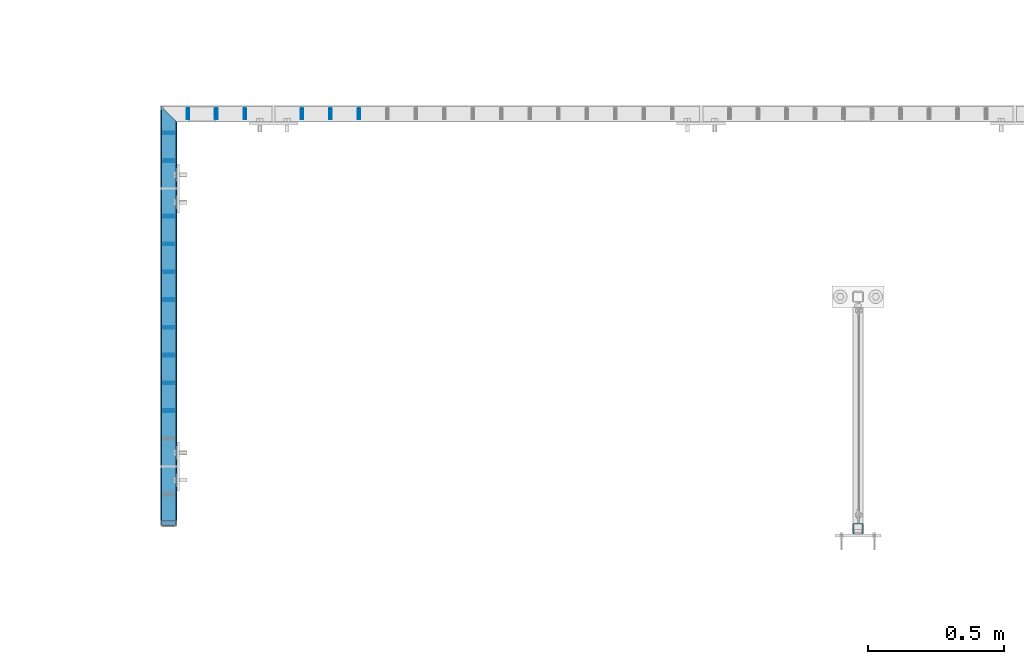
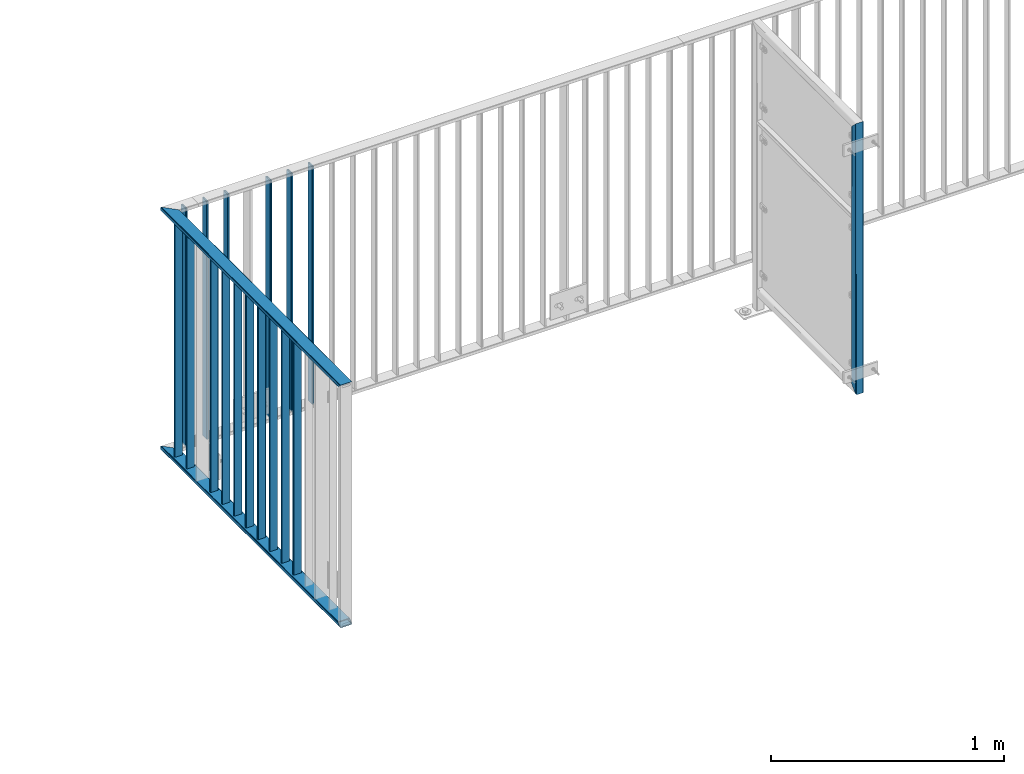
# One storey, part 25 of 156: 19 beams, 3 elements without a shape of their own.
"""IFC2X3 building model written with IfcOpenShell, lengths in millimetres."""

from ifc_helpers import new_model, si_unit, frame, origin_with_axes, origin_2d_with_axis, place, context, subcontext, project, spatial, hollow_rectangle, extrude, clip, halfspace, material, type_object, element, aggregate, save


model = new_model("IFC2X3")

# Units and contexts
model_context = context("Model", 3, precision=1e-05, world=origin_with_axes())
body_context = subcontext(model_context, "Body", "Model", "MODEL_VIEW")
ifc_project = project(units=[si_unit("LENGTHUNIT", "METRE", prefix="MILLI"), si_unit("AREAUNIT", "SQUARE_METRE"), si_unit("VOLUMEUNIT", "CUBIC_METRE"), si_unit("MASSUNIT", "GRAM", prefix="KILO"), si_unit("TIMEUNIT", "SECOND"), si_unit("PLANEANGLEUNIT", "RADIAN"), si_unit("SOLIDANGLEUNIT", "STERADIAN"), si_unit("THERMODYNAMICTEMPERATUREUNIT", "DEGREE_CELSIUS"), si_unit("LUMINOUSINTENSITYUNIT", "LUMEN")], contexts=[model_context])

# Site, building, storey
site_placement = place(None, origin_with_axes())
site = spatial("IfcSite", under=ifc_project, at=site_placement, CompositionType="ELEMENT")
building_placement = place(site_placement, origin_with_axes())
building = spatial("IfcBuilding", under=site, at=building_placement, Name="Undefined", CompositionType="ELEMENT")
storey_placement = place(building_placement, origin_with_axes())
storey = spatial("IfcBuildingStorey", under=building, at=storey_placement, Name="Undefined", CompositionType="ELEMENT", Elevation=0.0)

# Assembly, beams
assembly_1_placement = place(storey_placement, origin_with_axes())
assembly_1 = element("IfcElementAssembly", 1, at=assembly_1_placement, inside=storey, AssemblyPlace="NOTDEFINED", PredefinedType="RIGID_FRAME")
ifc_material = material(Name="STEEL/S235JR")
beam_type_1 = type_object("IfcBeamType", Name="K60/20/2", PredefinedType="NOTDEFINED")
beam_1_placement = place(assembly_1_placement, frame((31474.9983520508, 21631.4407649855, 2740.0), z_axis=(1.0, 0.0, 0.0), x_axis=(0.0, -1.0, 0.0)))
beam_1 = element("IfcBeam", 2, at=beam_1_placement, type_object=beam_type_1, material=ifc_material, ObjectType="K60/20/2", context=body_context, shape_type="Clipping", body=[
    clip(clip(extrude(hollow_rectangle(XDim=20.0, YDim=60.0, WallThickness=2.0, InnerFilletRadius=2.0, OuterFilletRadius=4.0, at=origin_2d_with_axis()), frame((1513.83911766303, 0.0, 0.0), z_axis=(-1.0, 0.0, 0.0), x_axis=(0.0, -1.0, 0.0)), (0.0, 0.0, 1.0), 1580.79), halfspace(frame((1483.43911766303, 10.0, 0.002166748046875), z_axis=(-0.707106781186548, 0.707106781186548, 0.0), x_axis=(0.0, 0.0, 1.0)), True)), halfspace(frame((3.44877025730966, 0.0, 30.0), z_axis=(-0.707106781186548, 0.0, 0.707106781186548), x_axis=(0.0, -1.0, 0.0)), False)),
])
beam_2_placement = place(assembly_1_placement, frame((31474.9983520508, 21631.4407649855, 3990.0), z_axis=(1.0, 0.0, 0.0), x_axis=(0.0, -1.0, 0.0)))
beam_2 = element("IfcBeam", 3, at=beam_2_placement, type_object=beam_type_1, material=ifc_material, ObjectType="K60/20/2", context=body_context, shape_type="Clipping", body=[
    clip(clip(extrude(hollow_rectangle(XDim=20.0, YDim=60.0, WallThickness=2.0, InnerFilletRadius=2.0, OuterFilletRadius=4.0, at=origin_2d_with_axis()), frame((1513.83911766303, 0.0, 0.0), z_axis=(-1.0, 0.0, 0.0), x_axis=(0.0, -1.0, 0.0)), (0.0, 0.0, 1.0), 1580.79), halfspace(frame((1463.43911766303, 10.0, 0.002166748046875), z_axis=(-0.707106781186548, -0.707106781186548, 0.0), x_axis=(0.0, 0.0, 1.0)), True)), halfspace(frame((-56.5512297426903, 0.0, -30.0), z_axis=(0.707106781186548, 0.0, -0.707106781186548), x_axis=(0.0, -1.0, 0.0)), True)),
])
beam_type_2 = type_object("IfcBeamType", Name="K40/10/1.5", PredefinedType="NOTDEFINED")
beam_3_placement = place(assembly_1_placement, frame((31474.9983597497, 20570.1907649865, 3980.00000000003), z_axis=(1.0, 0.0, 0.0), x_axis=(0.0, 0.0, -1.0)))
beam_3 = element("IfcBeam", 4, at=beam_3_placement, type_object=beam_type_2, material=ifc_material, ObjectType="K40/10/1.5", context=body_context, shape_type="Clipping", body=[
    clip(clip(extrude(hollow_rectangle(XDim=10.0, YDim=40.0, WallThickness=1.5, InnerFilletRadius=1.5, OuterFilletRadius=3.0, at=origin_2d_with_axis()), frame((1237.00000000003, 0.0, 0.0), z_axis=(-1.0, 0.0, 0.0), x_axis=(0.0, -1.0, 0.0)), (0.0, 0.0, 1.0), 1244.0), halfspace(frame((1237.00000000003, 3.63803898150218, 46.7940496082883), z_axis=(1.0, 0.0, 0.0), x_axis=(0.0, -0.758923924280425, -0.65117929724063)), False)), halfspace(frame((-6.99999999997453, -3.63803898149854, 46.7940496082956), z_axis=(-1.0, 0.0, 0.0), x_axis=(0.0, 0.75892392428044, -0.651179297240612)), False)),
])
beam_4_placement = place(assembly_1_placement, frame((31474.9983597497, 20671.9707649865, 3980.00000000003), z_axis=(1.0, 0.0, 0.0), x_axis=(0.0, 0.0, -1.0)))
beam_4 = element("IfcBeam", 5, at=beam_4_placement, type_object=beam_type_2, material=ifc_material, ObjectType="K40/10/1.5", context=body_context, shape_type="Clipping", body=[
    clip(clip(extrude(hollow_rectangle(XDim=10.0, YDim=40.0, WallThickness=1.5, InnerFilletRadius=1.5, OuterFilletRadius=3.0, at=origin_2d_with_axis()), frame((1237.00000000003, 0.0, 0.0), z_axis=(-1.0, 0.0, 0.0), x_axis=(0.0, -1.0, 0.0)), (0.0, 0.0, 1.0), 1244.0), halfspace(frame((1237.00000000003, 3.63803898150218, 46.7940496082883), z_axis=(1.0, 0.0, 0.0), x_axis=(0.0, -0.758923924280425, -0.65117929724063)), False)), halfspace(frame((-6.99999999997453, -3.63803898149854, 46.7940496082956), z_axis=(-1.0, 0.0, 0.0), x_axis=(0.0, 0.75892392428044, -0.651179297240612)), False)),
])
beam_5_placement = place(assembly_1_placement, frame((31474.9983597497, 20773.7507649865, 3980.00000000003), z_axis=(1.0, 0.0, 0.0), x_axis=(0.0, 0.0, -1.0)))
beam_5 = element("IfcBeam", 6, at=beam_5_placement, type_object=beam_type_2, material=ifc_material, ObjectType="K40/10/1.5", context=body_context, shape_type="Clipping", body=[
    clip(clip(extrude(hollow_rectangle(XDim=10.0, YDim=40.0, WallThickness=1.5, InnerFilletRadius=1.5, OuterFilletRadius=3.0, at=origin_2d_with_axis()), frame((1237.00000000003, 0.0, 0.0), z_axis=(-1.0, 0.0, 0.0), x_axis=(0.0, -1.0, 0.0)), (0.0, 0.0, 1.0), 1244.0), halfspace(frame((1237.00000000003, 3.63803898150218, 46.7940496082883), z_axis=(1.0, 0.0, 0.0), x_axis=(0.0, -0.758923924280425, -0.65117929724063)), False)), halfspace(frame((-6.99999999997453, -3.63803898149854, 46.7940496082956), z_axis=(-1.0, 0.0, 0.0), x_axis=(0.0, 0.75892392428044, -0.651179297240612)), False)),
])
beam_6_placement = place(assembly_1_placement, frame((31474.9983597497, 20875.5307649865, 3980.00000000003), z_axis=(1.0, 0.0, 0.0), x_axis=(0.0, 0.0, -1.0)))
beam_6 = element("IfcBeam", 7, at=beam_6_placement, type_object=beam_type_2, material=ifc_material, ObjectType="K40/10/1.5", context=body_context, shape_type="Clipping", body=[
    clip(clip(extrude(hollow_rectangle(XDim=10.0, YDim=40.0, WallThickness=1.5, InnerFilletRadius=1.5, OuterFilletRadius=3.0, at=origin_2d_with_axis()), frame((1237.00000000003, 0.0, 0.0), z_axis=(-1.0, 0.0, 0.0), x_axis=(0.0, -1.0, 0.0)), (0.0, 0.0, 1.0), 1244.0), halfspace(frame((1237.00000000003, 3.63803898150218, 46.7940496082883), z_axis=(1.0, 0.0, 0.0), x_axis=(0.0, -0.758923924280425, -0.65117929724063)), False)), halfspace(frame((-6.99999999997453, -3.63803898149854, 46.7940496082956), z_axis=(-1.0, 0.0, 0.0), x_axis=(0.0, 0.75892392428044, -0.651179297240612)), False)),
])
beam_7_placement = place(assembly_1_placement, frame((31474.9983597497, 20977.3107649865, 3980.00000000003), z_axis=(1.0, 0.0, 0.0), x_axis=(0.0, 0.0, -1.0)))
beam_7 = element("IfcBeam", 8, at=beam_7_placement, type_object=beam_type_2, material=ifc_material, ObjectType="K40/10/1.5", context=body_context, shape_type="Clipping", body=[
    clip(clip(extrude(hollow_rectangle(XDim=10.0, YDim=40.0, WallThickness=1.5, InnerFilletRadius=1.5, OuterFilletRadius=3.0, at=origin_2d_with_axis()), frame((1237.00000000003, 0.0, 0.0), z_axis=(-1.0, 0.0, 0.0), x_axis=(0.0, -1.0, 0.0)), (0.0, 0.0, 1.0), 1244.0), halfspace(frame((1237.00000000003, 3.63803898150218, 46.7940496082883), z_axis=(1.0, 0.0, 0.0), x_axis=(0.0, -0.758923924280425, -0.65117929724063)), False)), halfspace(frame((-6.99999999997453, -3.63803898149854, 46.7940496082956), z_axis=(-1.0, 0.0, 0.0), x_axis=(0.0, 0.75892392428044, -0.651179297240612)), False)),
])
beam_8_placement = place(assembly_1_placement, frame((31474.9983597497, 21079.0907649865, 3980.00000000003), z_axis=(1.0, 0.0, 0.0), x_axis=(0.0, 0.0, -1.0)))
beam_8 = element("IfcBeam", 9, at=beam_8_placement, type_object=beam_type_2, material=ifc_material, ObjectType="K40/10/1.5", context=body_context, shape_type="Clipping", body=[
    clip(clip(extrude(hollow_rectangle(XDim=10.0, YDim=40.0, WallThickness=1.5, InnerFilletRadius=1.5, OuterFilletRadius=3.0, at=origin_2d_with_axis()), frame((1237.00000000003, 0.0, 0.0), z_axis=(-1.0, 0.0, 0.0), x_axis=(0.0, -1.0, 0.0)), (0.0, 0.0, 1.0), 1244.0), halfspace(frame((1237.00000000003, 3.63803898150218, 46.7940496082883), z_axis=(1.0, 0.0, 0.0), x_axis=(0.0, -0.758923924280425, -0.65117929724063)), False)), halfspace(frame((-6.99999999997453, -3.63803898149854, 46.7940496082956), z_axis=(-1.0, 0.0, 0.0), x_axis=(0.0, 0.75892392428044, -0.651179297240612)), False)),
])
beam_9_placement = place(assembly_1_placement, frame((31474.9983597497, 21180.8707649865, 3980.00000000003), z_axis=(1.0, 0.0, 0.0), x_axis=(0.0, 0.0, -1.0)))
beam_9 = element("IfcBeam", 10, at=beam_9_placement, type_object=beam_type_2, material=ifc_material, ObjectType="K40/10/1.5", context=body_context, shape_type="Clipping", body=[
    clip(clip(extrude(hollow_rectangle(XDim=10.0, YDim=40.0, WallThickness=1.5, InnerFilletRadius=1.5, OuterFilletRadius=3.0, at=origin_2d_with_axis()), frame((1237.00000000003, 0.0, 0.0), z_axis=(-1.0, 0.0, 0.0), x_axis=(0.0, -1.0, 0.0)), (0.0, 0.0, 1.0), 1244.0), halfspace(frame((1237.00000000003, 3.63803898150218, 46.7940496082883), z_axis=(1.0, 0.0, 0.0), x_axis=(0.0, -0.758923924280425, -0.65117929724063)), False)), halfspace(frame((-6.99999999997453, -3.63803898149854, 46.7940496082956), z_axis=(-1.0, 0.0, 0.0), x_axis=(0.0, 0.75892392428044, -0.651179297240612)), False)),
])
beam_10_placement = place(assembly_1_placement, frame((31474.9983597497, 21282.6507649865, 3980.00000000003), z_axis=(1.0, 0.0, 0.0), x_axis=(0.0, 0.0, -1.0)))
beam_10 = element("IfcBeam", 11, at=beam_10_placement, type_object=beam_type_2, material=ifc_material, ObjectType="K40/10/1.5", context=body_context, shape_type="Clipping", body=[
    clip(clip(extrude(hollow_rectangle(XDim=10.0, YDim=40.0, WallThickness=1.5, InnerFilletRadius=1.5, OuterFilletRadius=3.0, at=origin_2d_with_axis()), frame((1237.00000000003, 0.0, 0.0), z_axis=(-1.0, 0.0, 0.0), x_axis=(0.0, -1.0, 0.0)), (0.0, 0.0, 1.0), 1244.0), halfspace(frame((1237.00000000003, 3.63803898150218, 46.7940496082883), z_axis=(1.0, 0.0, 0.0), x_axis=(0.0, -0.758923924280425, -0.65117929724063)), False)), halfspace(frame((-6.99999999997453, -3.63803898149854, 46.7940496082956), z_axis=(-1.0, 0.0, 0.0), x_axis=(0.0, 0.75892392428044, -0.651179297240612)), False)),
])

assembly_2_placement = place(storey_placement, origin_with_axes())
assembly_2 = element("IfcElementAssembly", 12, at=assembly_2_placement, inside=storey, AssemblyPlace="NOTDEFINED", PredefinedType="RIGID_FRAME")
beam_11_placement = place(assembly_2_placement, frame((31753.8485961914, 21657.9919947282, 3980.00000000003), z_axis=(0.0, -1.0, 0.0), x_axis=(0.0, 0.0, -1.0)))
beam_11 = element("IfcBeam", 13, at=beam_11_placement, type_object=beam_type_2, material=ifc_material, ObjectType="K40/10/1.5", context=body_context, shape_type="Clipping", body=[
    clip(clip(extrude(hollow_rectangle(XDim=10.0, YDim=40.0, WallThickness=1.5, InnerFilletRadius=1.5, OuterFilletRadius=3.0, at=origin_2d_with_axis()), frame((1237.00000000003, 0.0, 0.0), z_axis=(-1.0, 0.0, 0.0), x_axis=(0.0, -1.0, 0.0)), (0.0, 0.0, 1.0), 1244.0), halfspace(frame((1237.00000000003, 4.34248751949781, 47.3810900558092), z_axis=(1.0, 0.0, 0.0), x_axis=(0.0, -0.768354814194188, -0.640024124158313)), False)), halfspace(frame((-6.99999999997453, -4.34248751950508, 47.3810900558092), z_axis=(-1.0, 0.0, 0.0), x_axis=(0.0, 0.7683548141934, -0.640024124159258)), False)),
])
beam_12_placement = place(assembly_2_placement, frame((31649.3785961914, 21657.9919947282, 3980.00000000003), z_axis=(0.0, -1.0, 0.0), x_axis=(0.0, 0.0, -1.0)))
beam_12 = element("IfcBeam", 14, at=beam_12_placement, type_object=beam_type_2, material=ifc_material, ObjectType="K40/10/1.5", context=body_context, shape_type="Clipping", body=[
    clip(clip(extrude(hollow_rectangle(XDim=10.0, YDim=40.0, WallThickness=1.5, InnerFilletRadius=1.5, OuterFilletRadius=3.0, at=origin_2d_with_axis()), frame((1237.00000000003, 0.0, 0.0), z_axis=(-1.0, 0.0, 0.0), x_axis=(0.0, -1.0, 0.0)), (0.0, 0.0, 1.0), 1244.0), halfspace(frame((1237.00000000003, 4.34248751949781, 47.3810900558092), z_axis=(1.0, 0.0, 0.0), x_axis=(0.0, -0.763991285051099, -0.645226562043109)), False)), halfspace(frame((-6.99999999997453, -4.34248751950508, 47.3810900558092), z_axis=(-1.0, 0.0, 0.0), x_axis=(0.0, 0.763991285051099, -0.645226562043109)), False)),
])
beam_13_placement = place(assembly_2_placement, frame((31962.7885961914, 21657.9919947282, 3980.00000000003), z_axis=(0.0, -1.0, 0.0), x_axis=(0.0, 0.0, -1.0)))
beam_13 = element("IfcBeam", 15, at=beam_13_placement, type_object=beam_type_2, material=ifc_material, ObjectType="K40/10/1.5", context=body_context, shape_type="Clipping", body=[
    clip(clip(extrude(hollow_rectangle(XDim=10.0, YDim=40.0, WallThickness=1.5, InnerFilletRadius=1.5, OuterFilletRadius=3.0, at=origin_2d_with_axis()), frame((1237.00000000003, 0.0, 0.0), z_axis=(-1.0, 0.0, 0.0), x_axis=(0.0, -1.0, 0.0)), (0.0, 0.0, 1.0), 1244.0), halfspace(frame((1237.00000000003, 4.34248751949781, 47.3810900558092), z_axis=(1.0, 0.0, 0.0), x_axis=(0.0, -0.768354814194188, -0.640024124158313)), False)), halfspace(frame((-6.99999999997453, -4.34248751950508, 47.3810900558092), z_axis=(-1.0, 0.0, 0.0), x_axis=(0.0, 0.7683548141934, -0.640024124159258)), False)),
])
beam_14_placement = place(assembly_2_placement, frame((32067.2585961914, 21657.9919947282, 3980.00000000003), z_axis=(0.0, -1.0, 0.0), x_axis=(0.0, 0.0, -1.0)))
beam_14 = element("IfcBeam", 16, at=beam_14_placement, type_object=beam_type_2, material=ifc_material, ObjectType="K40/10/1.5", context=body_context, shape_type="Clipping", body=[
    clip(clip(extrude(hollow_rectangle(XDim=10.0, YDim=40.0, WallThickness=1.5, InnerFilletRadius=1.5, OuterFilletRadius=3.0, at=origin_2d_with_axis()), frame((1237.00000000003, 0.0, 0.0), z_axis=(-1.0, 0.0, 0.0), x_axis=(0.0, -1.0, 0.0)), (0.0, 0.0, 1.0), 1244.0), halfspace(frame((1237.00000000003, 4.34248751949781, 47.3810900558092), z_axis=(1.0, 0.0, 0.0), x_axis=(0.0, -0.768354814194188, -0.640024124158313)), False)), halfspace(frame((-6.99999999997453, -4.34248751950508, 47.3810900558092), z_axis=(-1.0, 0.0, 0.0), x_axis=(0.0, 0.7683548141934, -0.640024124159258)), False)),
])
beam_15_placement = place(assembly_2_placement, frame((32171.7285961914, 21657.9919947282, 3980.00000000003), z_axis=(0.0, -1.0, 0.0), x_axis=(0.0, 0.0, -1.0)))
beam_15 = element("IfcBeam", 17, at=beam_15_placement, type_object=beam_type_2, material=ifc_material, ObjectType="K40/10/1.5", context=body_context, shape_type="Clipping", body=[
    clip(clip(extrude(hollow_rectangle(XDim=10.0, YDim=40.0, WallThickness=1.5, InnerFilletRadius=1.5, OuterFilletRadius=3.0, at=origin_2d_with_axis()), frame((1237.00000000003, 0.0, 0.0), z_axis=(-1.0, 0.0, 0.0), x_axis=(0.0, -1.0, 0.0)), (0.0, 0.0, 1.0), 1244.0), halfspace(frame((1237.00000000003, 4.34248751949781, 47.3810900558092), z_axis=(1.0, 0.0, 0.0), x_axis=(0.0, -0.768354814194188, -0.640024124158313)), False)), halfspace(frame((-6.99999999997453, -4.34248751950508, 47.3810900558092), z_axis=(-1.0, 0.0, 0.0), x_axis=(0.0, 0.7683548141934, -0.640024124159258)), False)),
])
aggregate(assembly_2, [beam_11, beam_12, beam_13, beam_14, beam_15])

# Beam
beam_16_placement = place(assembly_1_placement, frame((31474.9983597497, 21486.2107649865, 3980.00000000003), z_axis=(1.0, 0.0, 0.0), x_axis=(0.0, 0.0, -1.0)))
beam_16 = element("IfcBeam", 18, at=beam_16_placement, type_object=beam_type_2, material=ifc_material, ObjectType="K40/10/1.5", context=body_context, shape_type="Clipping", body=[
    clip(clip(extrude(hollow_rectangle(XDim=10.0, YDim=40.0, WallThickness=1.5, InnerFilletRadius=1.5, OuterFilletRadius=3.0, at=origin_2d_with_axis()), frame((1237.00000000003, 0.0, 0.0), z_axis=(-1.0, 0.0, 0.0), x_axis=(0.0, -1.0, 0.0)), (0.0, 0.0, 1.0), 1244.0), halfspace(frame((1237.00000000003, 3.2449841921989, 46.4665039507236), z_axis=(1.0, 0.0, 0.0), x_axis=(0.0, -0.754414263122933, -0.656398598106883)), False)), halfspace(frame((-6.99999999997453, -3.24498419219526, 46.4665039507308), z_axis=(-1.0, 0.0, 0.0), x_axis=(0.0, 0.75441426312288, -0.656398598106944)), False)),
])

beam_17_placement = place(assembly_1_placement, frame((31544.998046875, 21657.9919947282, 3980.00000000003), z_axis=(0.0, -1.0, 0.0), x_axis=(0.0, 0.0, -1.0)))
beam_17 = element("IfcBeam", 19, at=beam_17_placement, type_object=beam_type_2, material=ifc_material, ObjectType="K40/10/1.5", context=body_context, shape_type="Clipping", body=[
    clip(clip(extrude(hollow_rectangle(XDim=10.0, YDim=40.0, WallThickness=1.5, InnerFilletRadius=1.5, OuterFilletRadius=3.0, at=origin_2d_with_axis()), frame((1237.00000000003, 0.0, 0.0), z_axis=(-1.0, 0.0, 0.0), x_axis=(0.0, -1.0, 0.0)), (0.0, 0.0, 1.0), 1244.0), halfspace(frame((1237.00000000003, 4.34248751949781, 47.3810900558092), z_axis=(1.0, 0.0, 0.0), x_axis=(0.0, -0.768354814194188, -0.640024124158313)), False)), halfspace(frame((-6.99999999997453, -4.34248751950508, 47.3810900558092), z_axis=(-1.0, 0.0, 0.0), x_axis=(0.0, 0.7683548141934, -0.640024124159258)), False)),
])

beam_18_placement = place(assembly_1_placement, frame((31474.9983597497, 21587.9907649865, 3980.00000000003), z_axis=(1.0, 0.0, 0.0), x_axis=(0.0, 0.0, -1.0)))
beam_18 = element("IfcBeam", 20, at=beam_18_placement, type_object=beam_type_2, material=ifc_material, ObjectType="K40/10/1.5", context=body_context, shape_type="Clipping", body=[
    clip(clip(extrude(hollow_rectangle(XDim=10.0, YDim=40.0, WallThickness=1.5, InnerFilletRadius=1.5, OuterFilletRadius=3.0, at=origin_2d_with_axis()), frame((1237.00000000003, 0.0, 0.0), z_axis=(-1.0, 0.0, 0.0), x_axis=(0.0, -1.0, 0.0)), (0.0, 0.0, 1.0), 1244.0), halfspace(frame((1237.00000000003, 0.531585963377438, 44.2053387614833), z_axis=(1.0, 0.0, 0.0), x_axis=(0.0, -0.72237744111132, -0.691498975106588)), False)), halfspace(frame((-6.99999999997453, -0.5315859633738, 44.2053387614833), z_axis=(-1.0, 0.0, 0.0), x_axis=(0.0, 0.722377441111346, -0.691498975106561)), False)),
])

aggregate(assembly_1, [beam_3, beam_4, beam_5, beam_6, beam_7, beam_8, beam_9, beam_10, beam_16, beam_17, beam_18, beam_1, beam_2])

# Assembly, beam
assembly_3_placement = place(storey_placement, origin_with_axes())
assembly_3 = element("IfcElementAssembly", 21, at=assembly_3_placement, inside=storey, AssemblyPlace="NOTDEFINED", PredefinedType="RIGID_FRAME")
beam_type_3 = type_object("IfcBeamType", Name="K40/3", PredefinedType="NOTDEFINED")
beam_19_placement = place(assembly_3_placement, frame((34000.0, 20138.0014343262, 4299.9999999525), z_axis=(1.0, 0.0, 0.0), x_axis=(0.0, 0.0, -1.0)))
beam_19 = element("IfcBeam", 22, at=beam_19_placement, type_object=beam_type_3, material=ifc_material, ObjectType="K40/3", context=body_context, shape_type="Clipping", body=[
    clip(clip(extrude(hollow_rectangle(XDim=40.0, YDim=40.0, WallThickness=3.0, InnerFilletRadius=3.0, OuterFilletRadius=6.0, at=origin_2d_with_axis()), frame((1240.4, 0.0, 0.0), z_axis=(-1.0, 0.0, 0.0), x_axis=(0.0, -1.0, 0.0)), (0.0, 0.0, 1.0), 1460.8), halfspace(frame((1180.0, 20.0, 0.0), z_axis=(-0.707106781186548, -0.707106781186548, 0.0), x_axis=(0.0, 0.0, 1.0)), True)), halfspace(frame((-200.0, -20.0, 0.0), z_axis=(0.707106781186548, -0.707106781186548, 0.0), x_axis=(0.0, 0.0, 1.0)), True)),
])
aggregate(assembly_3, [beam_19])

save(model, "model.ifc")
